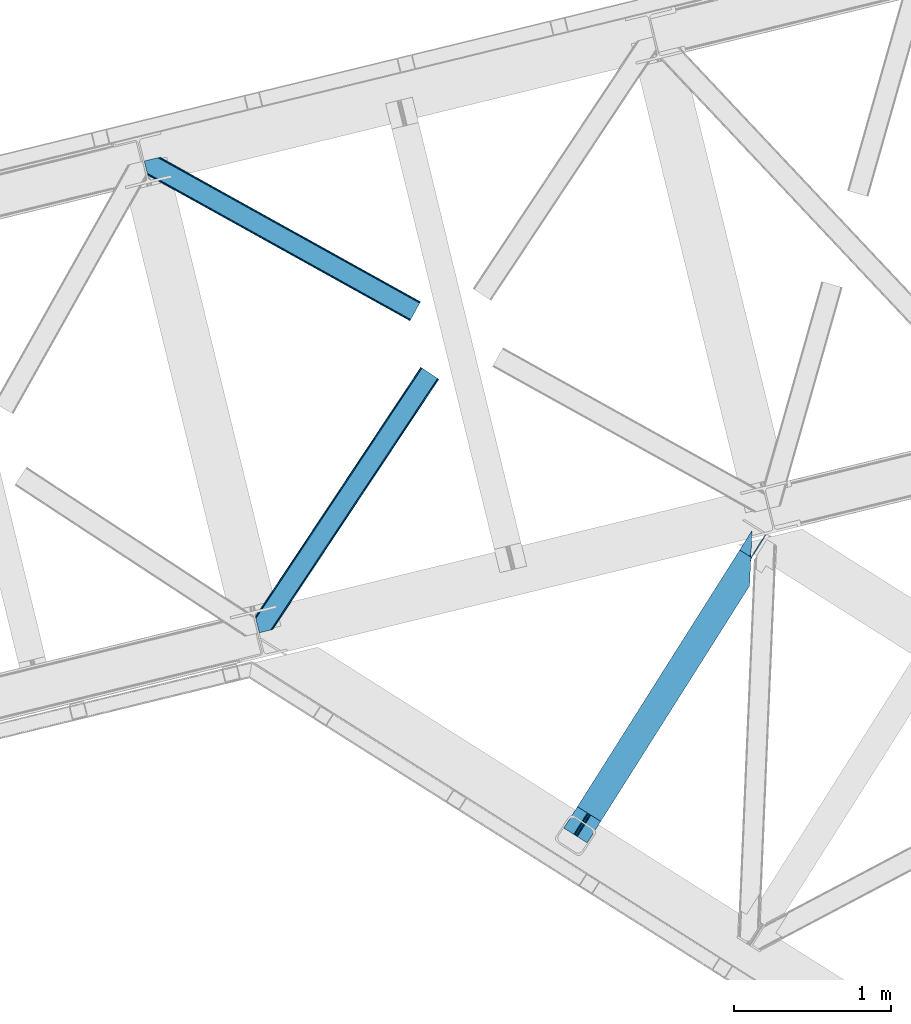
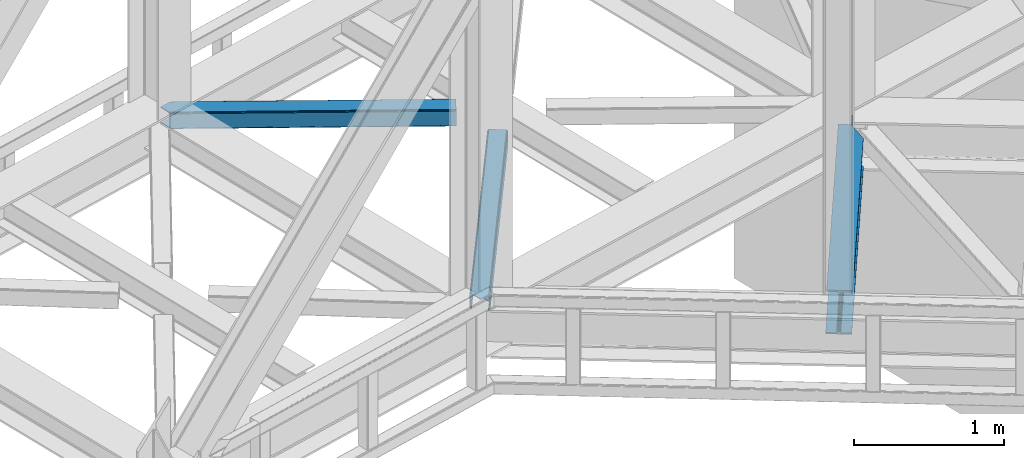
# One storey, part 82 of 92: 2 members, 1 beam.
"""IFC4 building model written with IfcOpenShell, lengths in millimetres."""

from ifc_helpers import new_model, entity, si_unit, converted_unit, derived_unit, direction, frame, origin, place, context, subcontext, project, spatial, triangles, type_object, element, save


model = new_model("IFC4")

# Units and contexts
model_context = context("Model", 3, precision=0.01, world=origin(), true_north=direction((6.12303176911189e-17, 1.0)))
plan_context = context("Plan", 3, precision=0.01, world=origin(), true_north=direction((6.12303176911189e-17, 1.0)))
body_context = subcontext(model_context, "Body", "Model", "MODEL_VIEW")
ifc_project = project(units=[si_unit("LENGTHUNIT", "METRE", prefix="MILLI"), si_unit("AREAUNIT", "SQUARE_METRE"), si_unit("VOLUMEUNIT", "CUBIC_METRE"), converted_unit("PLANEANGLEUNIT", "DEGREE", entity("IfcRatioMeasure", 0.0174532925199433), si_unit("PLANEANGLEUNIT", "RADIAN"), dimensions=[0, 0, 0, 0, 0, 0, 0]), si_unit("MASSUNIT", "GRAM", prefix="KILO"), derived_unit("MASSDENSITYUNIT", [(si_unit("MASSUNIT", "GRAM", prefix="KILO"), 1), (si_unit("LENGTHUNIT", "METRE"), -3)]), derived_unit("MOMENTOFINERTIAUNIT", [(si_unit("LENGTHUNIT", "METRE"), 4)]), si_unit("TIMEUNIT", "SECOND"), si_unit("FREQUENCYUNIT", "HERTZ"), si_unit("THERMODYNAMICTEMPERATUREUNIT", "DEGREE_CELSIUS"), derived_unit("THERMALTRANSMITTANCEUNIT", [(si_unit("MASSUNIT", "GRAM", prefix="KILO"), 1), (si_unit("THERMODYNAMICTEMPERATUREUNIT", "KELVIN"), -1), (si_unit("TIMEUNIT", "SECOND"), -3)]), derived_unit("VOLUMETRICFLOWRATEUNIT", [(si_unit("LENGTHUNIT", "METRE"), 3), (si_unit("TIMEUNIT", "SECOND"), -1)]), derived_unit("MASSFLOWRATEUNIT", [(si_unit("MASSUNIT", "GRAM", prefix="KILO"), 1), (si_unit("TIMEUNIT", "SECOND"), -1)]), derived_unit("ROTATIONALFREQUENCYUNIT", [(si_unit("TIMEUNIT", "SECOND"), -1)]), si_unit("ELECTRICCURRENTUNIT", "AMPERE"), si_unit("ELECTRICVOLTAGEUNIT", "VOLT"), si_unit("POWERUNIT", "WATT"), si_unit("FORCEUNIT", "NEWTON", prefix="KILO"), si_unit("ILLUMINANCEUNIT", "LUX"), si_unit("LUMINOUSFLUXUNIT", "LUMEN"), si_unit("LUMINOUSINTENSITYUNIT", "CANDELA"), derived_unit("USERDEFINED", [(si_unit("MASSUNIT", "GRAM", prefix="KILO"), -1), (si_unit("LENGTHUNIT", "METRE"), -2), (si_unit("TIMEUNIT", "SECOND"), 3), (si_unit("LUMINOUSFLUXUNIT", "LUMEN"), 1)]), derived_unit("LINEARVELOCITYUNIT", [(si_unit("LENGTHUNIT", "METRE"), 1), (si_unit("TIMEUNIT", "SECOND"), -1)]), si_unit("PRESSUREUNIT", "PASCAL"), derived_unit("USERDEFINED", [(si_unit("LENGTHUNIT", "METRE"), -2), (si_unit("MASSUNIT", "GRAM", prefix="KILO"), 1), (si_unit("TIMEUNIT", "SECOND"), -2)]), derived_unit("LINEARFORCEUNIT", [(si_unit("MASSUNIT", "GRAM", prefix="KILO"), 1), (si_unit("LENGTHUNIT", "METRE"), 1), (si_unit("TIMEUNIT", "SECOND"), -2), (si_unit("LENGTHUNIT", "METRE"), -1)]), derived_unit("PLANARFORCEUNIT", [(si_unit("MASSUNIT", "GRAM", prefix="KILO"), 1), (si_unit("LENGTHUNIT", "METRE"), 1), (si_unit("TIMEUNIT", "SECOND"), -2), (si_unit("LENGTHUNIT", "METRE"), -2)])], contexts=[model_context, plan_context])

# Site, building, storey
site_placement = place(None, origin())
site = spatial("IfcSite", under=ifc_project, at=site_placement, CompositionType="ELEMENT")
building_placement = place(site_placement, origin())
building = spatial("IfcBuilding", under=site, at=building_placement, CompositionType="ELEMENT")
storey_placement = place(building_placement, frame((0.0, 0.0, 15900.0)))
storey = spatial("IfcBuildingStorey", under=building, at=storey_placement, Name="05", CompositionType="ELEMENT", Elevation=15900.0)

# Beam
beam_type = type_object("IfcBeamType", PredefinedType="BEAM")
beam_placement = place(storey_placement, frame((-3471.98, 14954.96, 3441.0)))
element("IfcBeam", 1, at=beam_placement, inside=storey, type_object=beam_type, ObjectType="Steel Beam", PredefinedType="BEAM", context=body_context, shape_type="Tessellation", body=[
    triangles([(1188.72613334656, 1816.41354675293, 231.001016235354), (1188.08329467773, 1793.75679016113, 228.315133666994), (1188.92815589905, 1796.73218994141, 227.02451477051), (1187.41618423462, 1786.02702941895, 231.001016235354), (1190.21528663635, 1815.46941833496, 227.191946411134), (1191.30315628052, 1805.13516540527, 223.385202026369), (1194.96863021851, 1812.46611328125, 221.003952026367), (1191.70894546509, 1814.52645263672, 223.385202026369), (1191.71897392273, 1805.96185913086, 223.115451049805), (163.219397735596, 181.395904541016, 216.999545288087), (1194.53856925964, 1812.73818969727, 216.999545288087), (164.249276733398, 180.744781494141, 223.122427368166), (167.180783843994, 178.891406250001, 228.315133666994), (1187.27709388733, 1782.76792602539, 231.782363891602), (1186.75067253113, 1770.47332763672, 233.000894165041), (171.567144012451, 176.117156982422, 231.782363891602), (176.744734954834, 172.846426391601, 233.000894165041), (1180.87254295349, 1633.92584838867, 233.000894165041), (234.219715118408, 136.50910949707, 233.000894165041), (1188.72613334656, 1816.41354675293, 244.000222778323), (1180.87254295349, 1633.92584838867, 244.000222778323), (234.219715118408, 136.50910949707, 244.000222778323), (1117.61957244873, 1861.36429138184, 244.000222778323), (86.3005462646483, 230.022006225587, 244.000222778323), (1117.61957244873, 1861.36429138184, 233.000894165041), (86.3005462646483, 230.022006225587, 233.000894165041), (1175.09905815125, 1825.02813720703, 233.000894165041), (143.779886627197, 193.685852050781, 233.000894165041), (1187.59422569275, 1817.12978210449, 223.122427368166), (1188.62410469055, 1816.47865905762, 216.999545288087), (157.300572967529, 185.135211181641, 216.999545288087), (156.270693969726, 185.786334228516, 223.122427368166), (1184.66271858215, 1818.98315734863, 228.315133666994), (153.339186859131, 187.639709472656, 228.315133666994), (1180.27214355469, 1821.75624389649, 231.782363891602), (148.953117370605, 190.413958740235, 231.782363891602), (1188.62410469055, 1816.47865905762, 204.000338745118), (1194.53856925964, 1812.73818969727, 204.000338745118), (163.219397735596, 181.395904541016, 204.000338745118), (157.300572967529, 185.135211181641, 204.000338745118), (1284.44601745605, 1954.95276489258, 203.000399780274), (1278.52704734802, 1958.6920715332, 203.000399780274), (1195.07443771362, 1813.58348693848, 203.000399780274), (1189.15546760559, 1817.32395629883, 203.000399780274), (1284.44601745605, 1954.95276489258, 120.000814819337), (1278.52704734802, 1958.6920715332, 120.000814819337), (162.88715057373, 180.872680664063, 203.058535766602), (156.76921005249, 184.291076660156, 203.000399780274), (76.9188514709472, 44.8867950439453, 203.000399780274), (71.0000267028809, 48.626101684571, 203.000399780274), (1200.5501209259, 1835.34494934082, 120.000814819337), (1199.94579734802, 1821.28883056641, 120.000814819337), (1196.02728652954, 1828.19306030274, 119.163656616212), (1195.42281761169, 1814.13694152832, 119.163656616212), (1192.19612503052, 1822.13180236816, 116.778918457032), (1191.59180145264, 1808.07568359375, 116.778918457032), (1189.63639755249, 1818.08088684082, 113.210531616212), (1189.03192863464, 1804.02476806641, 113.210531616212), (1188.73383636475, 1816.65771789551, 109.000323486329), (1188.12951278687, 1802.6015991211, 109.000323486329), (1188.95184631348, 1817.00072021484, 203.077139282228), (1188.73383636475, 1816.65771789551, 27.0006774902358), (71.0000267028809, 48.626101684571, 27.0006774902358), (1189.59076080322, 1836.49139099121, 12.2178588867209), (1190.11718215942, 1848.78598937988, 11.0004913330085), (57.4793403625486, 57.1779052734382, 11.0004913330085), (62.6525711059571, 53.9048492431648, 12.2178588867209), (1189.13977088928, 1826.06760864258, 15.6862518310554), (67.0432914733888, 51.1317626953132, 15.6862518310554), (1188.84124259949, 1819.10291748047, 20.877795410157), (69.9747985839845, 49.2783874511715, 20.877795410157), (1195.99080619812, 1985.3323059082, 11.0004913330085), (0.0, 93.5140594482418, 11.0004913330085), (1195.99080619812, 1985.3323059082, 0.0), (0.0, 93.5140594482418, 0.0), (1180.87254295349, 1633.92584838867, 0.0), (147.91916885376, 0.0, 0.0), (85.2665977478027, 39.6080474853516, 12.2178588867209), (80.8802375793457, 42.3822967529304, 15.6862518310554), (76.9188514709472, 44.8867950439453, 27.0006774902358), (77.94873046875, 44.2356719970703, 20.877795410157), (90.4441886901855, 36.3373168945309, 11.0004913330085), (147.91916885376, 0.0, 11.0004913330085), (1187.27709388733, 1782.76792602539, 12.2178588867209), (1186.75067253113, 1770.47332763672, 11.0004913330085), (1188.02661209106, 1800.15639953613, 20.877795410157), (1187.7279384613, 1793.19170837402, 15.6862518310554), (1188.12951278687, 1802.6015991211, 27.0006774902358), (1180.87254295349, 1633.92584838867, 11.0004913330085)], [[1, 2, 3], [1, 4, 2], [5, 3, 6], [7, 8, 9], [6, 9, 8], [6, 8, 5], [3, 5, 1], [10, 11, 9], [11, 7, 9], [12, 9, 6], [6, 13, 12], [6, 3, 13], [2, 13, 3], [13, 4, 14], [13, 2, 4], [14, 15, 16], [17, 16, 15], [14, 16, 13], [9, 12, 10], [15, 18, 17], [19, 17, 18], [20, 14, 4], [14, 20, 15], [4, 1, 20], [21, 15, 20], [21, 18, 15], [18, 21, 22], [22, 19, 18], [21, 23, 24], [23, 21, 20], [24, 22, 21], [23, 25, 24], [26, 24, 25], [25, 27, 28], [28, 26, 25], [29, 30, 31], [31, 32, 29], [33, 29, 34], [32, 34, 29], [35, 33, 34], [34, 36, 35], [27, 35, 36], [36, 28, 27], [1, 35, 20], [8, 7, 11], [30, 11, 37], [37, 11, 38], [8, 29, 5], [11, 30, 8], [5, 33, 1], [27, 20, 35], [33, 5, 29], [30, 29, 8], [33, 35, 1], [27, 23, 20], [23, 27, 25], [13, 16, 36], [17, 22, 24], [19, 22, 17], [16, 17, 28], [10, 12, 32], [12, 13, 32], [39, 10, 40], [34, 13, 36], [24, 28, 17], [28, 36, 16], [24, 26, 28], [32, 31, 10], [31, 40, 10], [34, 32, 13], [41, 42, 43], [44, 43, 42], [41, 45, 42], [46, 42, 45], [47, 48, 49], [50, 49, 48], [46, 45, 51], [52, 51, 45], [51, 52, 53], [54, 53, 52], [53, 54, 55], [56, 55, 54], [57, 55, 56], [56, 58, 57], [59, 57, 58], [58, 60, 59], [57, 37, 61], [57, 61, 55], [53, 55, 61], [42, 46, 51], [51, 61, 42], [61, 51, 53], [62, 48, 59], [59, 48, 31], [63, 48, 62], [63, 50, 48], [31, 37, 59], [59, 37, 57], [31, 30, 37], [64, 65, 66], [66, 67, 64], [68, 64, 67], [67, 69, 68], [70, 68, 69], [69, 71, 70], [62, 70, 71], [71, 63, 62], [65, 72, 73], [73, 66, 65], [72, 74, 75], [75, 73, 72], [74, 76, 75], [77, 75, 76], [78, 79, 67], [80, 71, 81], [79, 81, 69], [80, 49, 63], [82, 75, 77], [77, 83, 82], [82, 78, 66], [67, 79, 69], [71, 80, 63], [50, 63, 49], [71, 69, 81], [75, 82, 66], [67, 66, 78], [73, 75, 66], [68, 64, 84], [65, 74, 76], [72, 74, 65], [64, 65, 85], [62, 70, 86], [70, 68, 87], [59, 62, 88], [87, 68, 84], [76, 85, 65], [85, 84, 64], [76, 89, 85], [86, 88, 62], [88, 60, 59], [87, 86, 70], [86, 88, 80], [80, 81, 86], [87, 86, 81], [81, 79, 87], [84, 87, 79], [79, 78, 84], [85, 84, 78], [78, 82, 85], [89, 85, 82], [82, 83, 89], [76, 89, 77], [83, 77, 89]]),
])

# Members
member_type_1 = type_object("IfcMemberType", PredefinedType="BRACE")
member_1_placement = place(storey_placement, frame((-5433.35, 16290.3, 3510.02)))
element("IfcMember", 2, at=member_1_placement, inside=storey, type_object=member_type_1, ObjectType="Steel Horizontal Brace", PredefinedType="BRACE", context=body_context, shape_type="Tessellation", body=[
    triangles([(1167.55605926514, 1611.29350891113, 17.5000946044929), (1167.55605926514, 1611.29350891113, 122.499499511719), (112.764628601074, 21.275445556641, 17.5000946044929), (112.764628601074, 21.275445556641, 122.499499511719), (1166.44769668579, 1612.03067321777, 129.196765136719), (110.858349609375, 20.810357666016, 129.196765136719), (1163.28451766968, 1614.12705688477, 134.87548828125), (105.426704406738, 19.486019897462, 134.87548828125), (1158.55573654175, 1617.26640014649, 138.668280029298), (97.3022003173828, 17.5059082031257, 138.668280029298), (1152.97613525391, 1620.96849975586, 140.000756835936), (87.713832092285, 15.1688415527351, 140.000756835936), (5.64326019287091, 81.3950317382823, 140.000756835936), (1065.47537155151, 1679.01263122559, 140.000756835936), (25.4839096069336, 0.0, 140.000756835936), (1059.89577026367, 1682.71473083496, 138.668280029298), (3.48350830078107, 90.2537933349613, 138.668280029298), (1055.16698913574, 1685.85407409668, 134.87548828125), (1.65280609130878, 97.7649627685551, 134.87548828125), (1052.00381011963, 1687.95045776367, 129.196765136719), (0.42962493896448, 102.7832611084, 129.196765136719), (1050.89573822022, 1688.68762207031, 122.499499511719), (0.0, 104.544781494142, 122.499499511719), (1050.89573822022, 1688.68762207031, 17.5000946044929), (0.0, 104.544781494142, 17.5000946044929), (1166.44769668579, 1612.03067321777, 10.8039916992202), (1163.28451766968, 1614.12705688477, 5.12643127441333), (159.822802734375, 95.9557708740231, 9.25873718261573), (160.257078552246, 97.3742889404293, 8.50064392089917), (159.407711791992, 100.858959960939, 5.12643127441333), (110.469419860839, 20.7150146484382, 10.8702667236321), (109.995030212403, 20.5999053955074, 9.50058288574292), (1152.97613525391, 1620.96849975586, 0.0), (1158.55573654175, 1617.26640014649, 1.33247680664135), (155.417839050293, 117.227728271484, 0.0), (157.577009582519, 108.368966674805, 1.33247680664135), (1065.47537155151, 1679.01263122559, 0.0), (121.558859252929, 256.129714965822, 0.0), (155.314356994629, 113.429122924807, 9.50058288574292), (90.5967956542972, 15.8711242675781, 9.50058288574292), (155.425978088379, 114.267443847655, 9.29594421386719), (155.539343261718, 115.1185546875, 9.08781738281323), (160.118714904786, 96.9219909667972, 8.74248962402271), (155.650964355469, 115.956875610353, 8.8831787109375), (155.446325683593, 117.1102935791, 8.50064392089917), (1152.72004623413, 1621.13593139648, 8.3320495605476), (1147.14073562622, 1624.83803100586, 7.00073547363354), (153.160418701172, 126.488790893554, 7.00073547363354), (1157.45347824097, 1617.99775085449, 12.1260040283196), (95.4092926025387, 17.0443084716808, 12.1260040283196), (1161.72501983643, 1615.16420288086, 24.5008300781265), (1160.61200637817, 1615.90020446777, 17.8035644531265), (102.742565917969, 18.8325714111324, 24.5008300781265), (100.835705566406, 18.3674835205074, 17.8035644531265), (1161.72501983643, 1615.16420288086, 115.499926757813), (102.742565917969, 18.8325714111324, 115.499926757813), (100.835705566406, 18.3674835205074, 122.197192382813), (87.2801376342777, 15.0630340576172, 131.668707275392), (77.6917694091799, 12.7259674072266, 133.00118408203), (25.4839096069336, 0.0, 133.00118408203), (95.4092926025387, 17.0443084716808, 127.875915527344), (1147.14073562622, 1624.83803100586, 133.00118408203), (1152.72004623413, 1621.13593139648, 131.668707275392), (1157.45347824097, 1617.99775085449, 127.875915527344), (1160.61200637817, 1615.90020446777, 122.197192382813), (7.90068054199219, 72.1351318359375, 133.00118408203), (1071.3107711792, 1675.14309997558, 133.00118408203), (1056.72648696899, 1684.81692810058, 115.499926757813), (1057.83950042725, 1684.0820892334, 122.197192382813), (2.25742034912128, 95.2848815917987, 115.499926757813), (2.68704528808576, 93.5233612060547, 122.197192382813), (1060.99802856445, 1681.98338012695, 127.875915527344), (3.91022644043005, 88.505062866212, 127.875915527344), (1065.73146057129, 1678.84636230469, 131.668707275392), (5.74092864990234, 80.9938934326183, 131.668707275392), (1060.99802856445, 1681.98338012695, 12.1260040283196), (1059.89577026367, 1682.71473083496, 1.33247680664135), (1055.16698913574, 1685.85407409668, 5.12643127441333), (1071.3107711792, 1675.14309997558, 7.00073547363354), (1065.73146057129, 1678.84636230469, 8.3320495605476), (1056.72648696899, 1684.81692810058, 24.5008300781265), (1052.00381011963, 1687.95045776367, 10.8039916992202), (1057.83950042725, 1684.0820892334, 17.8035644531265), (2.25742034912128, 95.2848815917987, 24.5008300781265), (123.816279602051, 246.869815063475, 7.00073547363354), (2.88121948242224, 92.7245727539066, 16.5001556396492), (2.77483062744159, 93.1629180908203, 17.8698394775383), (0.0093017578128638, 104.50757446289, 16.5001556396492), (119.399688720703, 264.988476562501, 1.33247680664135), (121.662922668457, 255.702996826172, 8.41343994140698), (117.568986511231, 272.499645996095, 5.12643127441333), (116.719619750977, 275.983154296877, 8.50064392089917), (4.73924560546857, 108.865447998049, 10.8714294433594), (115.787118530274, 275.584341430664, 9.50058288574292), (5.89266357421911, 109.927011108399, 9.50058288574292), (7.20479278564471, 93.4687133789066, 12.1260040283196), (120.157200622559, 257.658691406252, 9.50058288574292), (121.184463500977, 256.801766967774, 8.80643920898365), (10.2621643066404, 92.0013610839851, 9.50058288574292)], [[1, 2, 3], [4, 3, 2], [2, 5, 4], [6, 4, 5], [5, 7, 6], [8, 6, 7], [7, 9, 8], [10, 8, 9], [9, 11, 10], [12, 10, 11], [11, 13, 12], [11, 14, 13], [13, 15, 12], [14, 16, 17], [17, 13, 14], [16, 18, 19], [19, 17, 16], [18, 20, 21], [21, 19, 18], [20, 22, 23], [23, 21, 20], [22, 24, 23], [25, 23, 24], [26, 1, 3], [27, 28, 29], [29, 30, 27], [26, 31, 28], [28, 27, 26], [31, 32, 28], [33, 34, 35], [36, 35, 34], [34, 27, 36], [30, 36, 27], [3, 31, 26], [37, 33, 38], [35, 38, 33], [39, 28, 32], [32, 40, 39], [39, 41, 28], [41, 42, 43], [42, 44, 43], [44, 45, 29], [46, 47, 48], [49, 46, 45], [45, 44, 49], [49, 42, 41], [42, 49, 44], [41, 39, 49], [49, 39, 50], [40, 50, 39], [48, 45, 46], [51, 52, 53], [54, 53, 52], [52, 49, 54], [50, 54, 49], [55, 51, 53], [53, 56, 55], [57, 4, 6], [58, 10, 12], [15, 59, 12], [59, 15, 60], [59, 58, 12], [61, 10, 58], [61, 57, 8], [8, 10, 61], [6, 8, 57], [53, 3, 4], [50, 32, 54], [57, 56, 4], [50, 40, 32], [53, 54, 3], [56, 53, 4], [31, 3, 54], [54, 32, 31], [62, 63, 58], [58, 59, 62], [63, 64, 61], [61, 58, 63], [64, 65, 57], [57, 61, 64], [65, 55, 56], [56, 57, 65], [62, 66, 67], [66, 62, 59], [60, 66, 59], [68, 69, 70], [71, 70, 69], [69, 72, 71], [73, 71, 72], [72, 74, 73], [75, 73, 74], [74, 67, 75], [66, 75, 67], [26, 49, 52], [51, 2, 1], [26, 52, 1], [26, 27, 49], [52, 51, 1], [49, 27, 34], [47, 33, 37], [33, 46, 34], [46, 33, 47], [46, 49, 34], [5, 64, 7], [55, 2, 51], [2, 65, 5], [65, 2, 55], [5, 65, 64], [11, 62, 14], [9, 7, 64], [64, 63, 9], [63, 62, 11], [11, 9, 63], [76, 77, 78], [37, 79, 47], [37, 80, 79], [80, 37, 77], [76, 80, 77], [81, 24, 22], [82, 83, 76], [78, 82, 76], [83, 82, 24], [81, 83, 24], [16, 72, 18], [14, 62, 67], [67, 74, 14], [74, 72, 16], [16, 14, 74], [20, 18, 72], [22, 68, 81], [69, 22, 20], [22, 69, 68], [69, 20, 72], [81, 68, 84], [70, 84, 68], [47, 79, 85], [85, 48, 47], [75, 66, 13], [66, 15, 13], [66, 60, 15], [17, 75, 13], [73, 17, 19], [73, 75, 17], [86, 87, 88], [23, 70, 71], [71, 19, 21], [19, 71, 73], [21, 23, 71], [23, 84, 70], [25, 88, 87], [25, 84, 23], [84, 25, 87], [85, 38, 48], [89, 90, 91], [90, 89, 38], [91, 90, 92], [38, 85, 90], [48, 38, 35], [36, 45, 35], [45, 36, 30], [35, 45, 48], [30, 29, 45], [24, 82, 93], [93, 25, 24], [94, 93, 82], [94, 95, 93], [78, 91, 92], [92, 82, 78], [92, 94, 82], [78, 77, 91], [89, 91, 77], [77, 37, 89], [38, 89, 37], [93, 88, 25], [83, 81, 84], [83, 86, 96], [83, 87, 86], [80, 97, 98], [76, 96, 97], [97, 80, 76], [96, 99, 97], [79, 80, 90], [90, 85, 79], [96, 76, 83], [84, 87, 83], [95, 96, 93], [95, 99, 96], [96, 88, 93], [86, 88, 96], [94, 97, 95], [99, 95, 97]]),
])
member_type_2 = type_object("IfcMemberType", PredefinedType="BRACE")
member_2_placement = place(storey_placement, frame((-6138.83, 18272.5, 3510.02)))
element("IfcMember", 3, at=member_2_placement, inside=storey, type_object=member_type_2, ObjectType="Steel Horizontal Brace", PredefinedType="BRACE", context=body_context, shape_type="Tessellation", body=[
    triangles([(1747.75785369873, 107.098114013672, 140.000756835936), (1751.00765533447, 112.952407836914, 138.668280029298), (86.0110290527336, 1037.46574401855, 138.668280029298), (76.4226608276367, 1035.12867736816, 140.000756835936), (1753.76620788574, 117.917221069336, 134.87548828125), (94.1355331420891, 1039.44585571289, 134.87548828125), (1755.6050491333, 121.232135009766, 129.196765136719), (99.5665969848633, 1040.77019348145, 129.196765136719), (1756.25442810059, 122.398342895507, 122.499499511719), (101.473457336426, 1041.23528137207, 122.499499511719), (1756.25442810059, 122.398342895507, 17.5000946044929), (101.473457336426, 1041.23528137207, 17.5000946044929), (1696.78712768555, 15.3002288818352, 140.000756835936), (16.6437515258785, 948.220028686523, 140.000756835936), (0.0, 1016.49958190918, 140.000756835936), (1688.29055328369, 0.0, 122.499499511719), (1688.935572052, 1.16504516601708, 129.196765136719), (22.2870117187495, 925.070278930663, 122.499499511719), (21.857386779785, 926.831799316406, 129.196765136719), (1690.77906417847, 4.48112182617115, 134.87548828125), (20.6342056274407, 931.85009765625, 134.87548828125), (1693.5326751709, 9.44477233886937, 138.668280029298), (18.8035034179684, 939.361267089844, 138.668280029298), (1688.29055328369, 0.0, 17.5000946044929), (22.2870117187495, 925.070278930663, 17.5000946044929), (1753.76620788574, 117.917221069336, 5.12643127441333), (1751.00765533447, 112.952407836914, 1.33247680664135), (163.947550964355, 994.188153076171, 1.33247680664135), (162.329626464843, 1000.82728271484, 4.50088806152417), (1755.6050491333, 121.232135009766, 10.8039916992202), (161.571533203125, 1001.83419799805, 5.00085754394604), (160.809370422363, 1002.84111328125, 5.50082702636792), (99.5665969848633, 1040.77019348145, 10.8039916992202), (94.6552688598631, 1039.57259216309, 5.50082702636792), (1747.75785369873, 107.098114013672, 0.0), (166.107302856445, 985.329391479492, 0.0), (1696.78712768555, 15.3002288818352, 0.0), (199.965701293945, 846.428567504885, 0.0), (203.74395904541, 830.930676269531, 4.50088806152417), (202.125453186035, 837.568643188479, 1.33247680664135), (22.0515609741205, 926.03533630371, 12.5003997802742), (23.5985595703123, 926.191140747073, 10.9621215820298), (1688.935572052, 1.16504516601708, 10.8039916992202), (202.882965087891, 830.238858032226, 5.50082702636792), (1690.77906417847, 4.48112182617115, 5.12643127441333), (29.0836898803709, 926.742269897462, 5.50082702636792), (1693.5326751709, 9.44477233886937, 1.33247680664135), (6.80074768066333, 1018.15762023926, 5.50082702636792), (20.9359313964842, 953.845266723634, 7.00073547363354), (21.5068267822262, 945.865521240234, 8.3320495605476), (5.34560394287109, 1017.80299072266, 7.00073547363354), (18.4942199707029, 940.629794311524, 12.5003997802742), (1700.1831413269, 21.4196228027358, 7.00073547363354), (66.4005981445307, 1032.68580322266, 7.00073547363354), (1744.36184005737, 100.978720092775, 7.00073547363354), (1694.17478713989, 10.6005157470718, 12.1260040283196), (1696.93333969116, 15.5653289794936, 8.3320495605476), (19.5999664306637, 936.091699218752, 17.8035644531265), (1691.69092712402, 6.12055664062427, 24.5008300781265), (1692.33594589233, 7.28443908691406, 17.8035644531265), (20.0295913696282, 934.33017883301, 24.5008300781265), (1747.61164169311, 106.833013916017, 8.3320495605476), (75.9889663696285, 1035.02286987305, 8.3320495605476), (1750.36554336548, 111.796664428712, 12.1260040283196), (84.1175399780268, 1037.00414428711, 12.1260040283196), (1752.20903549194, 115.112741088869, 17.8035644531265), (89.5445343017573, 1038.32731933594, 17.8035644531265), (1752.85405426025, 116.277786254883, 24.5008300781265), (91.4560455322262, 1038.79240722656, 24.5008300781265), (1752.85405426025, 116.277786254883, 115.499926757813), (91.4560455322262, 1038.79240722656, 115.499926757813), (84.1175399780268, 1037.00414428711, 127.875915527344), (75.9889663696285, 1035.02286987305, 131.668707275392), (89.5445343017573, 1038.32731933594, 122.197192382813), (66.4005981445307, 1032.68580322266, 133.00118408203), (0.0, 1016.49958190918, 133.00118408203), (1752.20903549194, 115.112741088869, 122.197192382813), (1750.36554336548, 111.796664428712, 127.875915527344), (1747.61164169311, 106.833013916017, 131.668707275392), (1744.36184005737, 100.978720092775, 133.00118408203), (1694.17478713989, 10.6005157470718, 127.875915527344), (1700.1831413269, 21.4196228027358, 133.00118408203), (1696.93333969116, 15.5653289794936, 131.668707275392), (1691.69092712402, 6.12055664062427, 115.499926757813), (1692.33594589233, 7.28443908691406, 122.197192382813), (19.5999664306637, 936.091699218752, 122.197192382813), (18.3767852783203, 941.109997558593, 127.875915527344), (20.0295913696282, 934.33017883301, 115.499926757813), (16.5460830688471, 948.621166992187, 131.668707275392), (14.3869125366209, 957.479928588869, 133.00118408203)], [[1, 2, 3], [3, 4, 1], [2, 5, 6], [6, 3, 2], [5, 7, 8], [8, 6, 5], [7, 9, 10], [10, 8, 7], [9, 11, 10], [12, 10, 11], [13, 4, 14], [4, 13, 1], [15, 14, 4], [16, 17, 18], [19, 18, 17], [17, 20, 19], [21, 19, 20], [20, 22, 21], [23, 21, 22], [22, 13, 23], [14, 23, 13], [24, 16, 25], [18, 25, 16], [26, 27, 28], [28, 29, 26], [30, 26, 31], [30, 32, 33], [34, 33, 32], [29, 31, 26], [27, 35, 36], [36, 28, 27], [11, 30, 12], [33, 12, 30], [35, 37, 38], [38, 36, 35], [29, 36, 38], [36, 29, 28], [38, 39, 29], [39, 38, 40], [24, 41, 42], [24, 25, 41], [43, 42, 44], [44, 45, 43], [42, 46, 44], [47, 45, 44], [37, 47, 40], [40, 38, 37], [39, 40, 47], [42, 43, 24], [46, 34, 32], [34, 46, 48], [32, 44, 46], [46, 49, 48], [49, 46, 50], [51, 48, 49], [52, 50, 46], [42, 41, 52], [42, 52, 46], [53, 54, 49], [54, 53, 55], [51, 49, 54], [56, 57, 50], [56, 52, 58], [59, 60, 61], [58, 61, 60], [58, 60, 56], [50, 52, 56], [57, 53, 50], [49, 50, 53], [55, 62, 63], [63, 54, 55], [62, 64, 65], [65, 63, 62], [64, 66, 67], [67, 65, 64], [66, 68, 69], [69, 67, 66], [68, 70, 71], [71, 69, 68], [72, 73, 3], [6, 72, 3], [74, 6, 8], [74, 10, 71], [6, 74, 72], [10, 74, 8], [73, 4, 3], [15, 75, 76], [15, 4, 75], [73, 75, 4], [10, 69, 71], [34, 65, 67], [67, 69, 12], [12, 69, 10], [67, 33, 34], [33, 67, 12], [48, 54, 34], [54, 63, 34], [63, 65, 34], [48, 51, 54], [70, 77, 71], [74, 71, 77], [77, 78, 74], [72, 74, 78], [78, 79, 72], [73, 72, 79], [79, 80, 73], [75, 73, 80], [7, 78, 77], [70, 11, 9], [7, 77, 9], [7, 5, 78], [77, 70, 9], [78, 5, 2], [80, 1, 13], [1, 79, 2], [79, 1, 80], [79, 78, 2], [30, 64, 26], [68, 11, 70], [11, 66, 30], [66, 11, 68], [30, 66, 64], [35, 55, 37], [27, 26, 64], [64, 62, 27], [62, 55, 35], [35, 27, 62], [81, 22, 20], [13, 82, 80], [13, 83, 82], [83, 13, 22], [81, 83, 22], [84, 16, 24], [17, 85, 81], [20, 17, 81], [85, 17, 16], [84, 85, 16], [47, 56, 45], [37, 55, 53], [53, 57, 37], [57, 56, 47], [47, 37, 57], [43, 45, 56], [24, 59, 84], [60, 24, 43], [24, 60, 59], [60, 43, 56], [86, 21, 87], [88, 61, 18], [19, 86, 18], [86, 19, 21], [86, 88, 18], [61, 25, 18], [58, 52, 41], [41, 25, 58], [61, 58, 25], [89, 23, 14], [15, 90, 14], [76, 90, 15], [89, 87, 23], [23, 87, 21], [90, 89, 14], [75, 82, 90], [75, 80, 82], [90, 76, 75], [84, 59, 61], [61, 88, 84], [82, 83, 89], [89, 90, 82], [83, 81, 87], [87, 89, 83], [81, 85, 86], [86, 87, 81], [85, 84, 88], [88, 86, 85]]),
])

save(model, "model.ifc")
